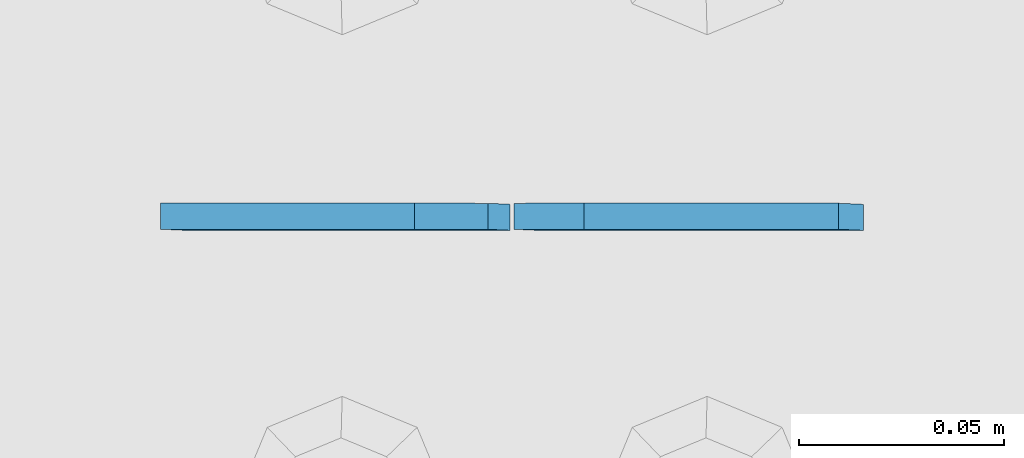
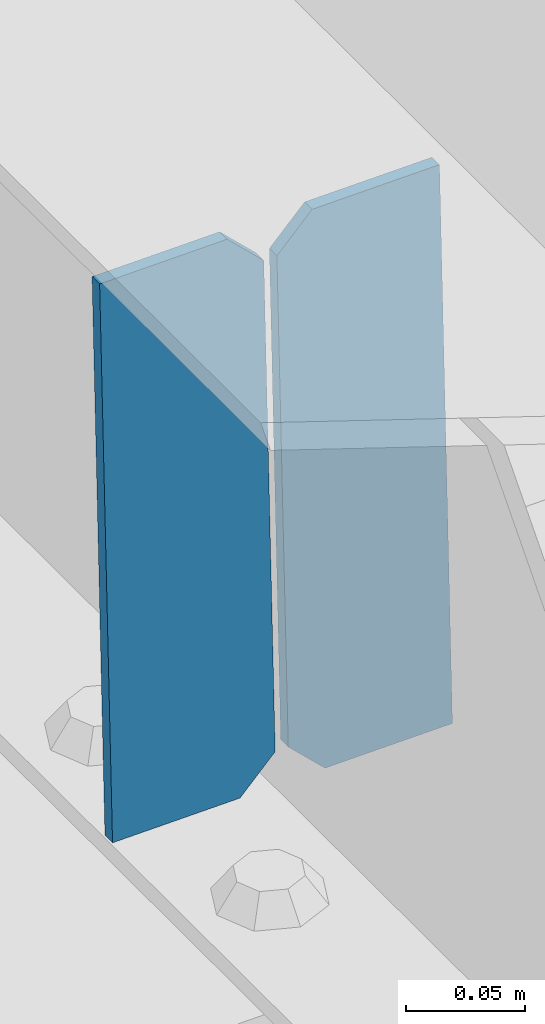
# One storey, part 3472 of 3843: 2 plates, 1 element without a shape of its own.
"""IFC2X3 building model written with IfcOpenShell, lengths in millimetres."""

from ifc_helpers import new_model, si_unit, frame, origin_with_axes, place, context, subcontext, project, spatial, faceted_brep, material, type_object, element, aggregate, save


model = new_model("IFC2X3")

# Units and contexts
model_context = context("Model", 3, precision=1e-05, world=origin_with_axes())
body_context = subcontext(model_context, "Body", "Model", "MODEL_VIEW")
ifc_project = project(units=[si_unit("LENGTHUNIT", "METRE", prefix="MILLI"), si_unit("AREAUNIT", "SQUARE_METRE"), si_unit("VOLUMEUNIT", "CUBIC_METRE"), si_unit("MASSUNIT", "GRAM", prefix="KILO"), si_unit("TIMEUNIT", "SECOND"), si_unit("PLANEANGLEUNIT", "RADIAN"), si_unit("SOLIDANGLEUNIT", "STERADIAN"), si_unit("THERMODYNAMICTEMPERATUREUNIT", "DEGREE_CELSIUS"), si_unit("LUMINOUSINTENSITYUNIT", "LUMEN")], contexts=[model_context])

# Site, building, storey
site_placement = place(None, origin_with_axes())
site = spatial("IfcSite", under=ifc_project, at=site_placement, CompositionType="ELEMENT")
building_placement = place(site_placement, origin_with_axes())
building = spatial("IfcBuilding", under=site, at=building_placement, Name="Undefined", CompositionType="ELEMENT")
storey_placement = place(building_placement, origin_with_axes())
storey = spatial("IfcBuildingStorey", under=building, at=storey_placement, Name="Undefined", CompositionType="ELEMENT", Elevation=0.0)

# Assembly, plates
assembly_placement = place(storey_placement, origin_with_axes())
assembly = element("IfcElementAssembly", 1, at=assembly_placement, inside=storey, Name="BEAM", AssemblyPlace="NOTDEFINED", PredefinedType="RIGID_FRAME")
ifc_material = material(Name="STEEL/A572-50")
plate_type = type_object("IfcPlateType", PredefinedType="NOTDEFINED")
plate_1_placement = place(assembly_placement, frame((54279.5464783436, 92214.2618382584, 45804.6277035639), z_axis=(-0.0211520977917899, 0.00096162699988054, 0.999775806884983), x_axis=(-0.999776269351802, -2.03449999561139e-05, -0.0211520880074371)))
plate_1 = element("IfcPlate", 2, at=plate_1_placement, type_object=plate_type, material=ifc_material, Name="STIFFENER", context=body_context, shape_type="Brep", body=[
    faceted_brep([(0.0, -3.17499999999927, 0.0), (6.83940015733242e-10, -3.17499999996653, 288.924999998613), (6.54836185276508e-10, 3.17500000001746, 288.924999998591), (0.0, 3.17499999999927, 0.0), (61.9125003828667, -3.17499999997744, 288.924999998599), (61.9125003828522, 3.17500000002838, 288.924999998584), (79.3750000013097, -3.17499999997744, 271.462500380039), (79.375000001266, 3.17500000002838, 271.462500380017), (79.375000000713, -3.17499999999927, 17.4624996185448), (79.3750000006694, 3.17500000000291, 17.462499618523), (61.9125003821828, -3.17499999999563, -1.45519152283669e-11), (61.9125003821682, 3.17500000000655, -2.91038304567337e-11)], [[[0, 1, 2, 3]], [[1, 4, 5, 2]], [[4, 6, 7, 5]], [[6, 8, 9, 7]], [[8, 10, 11, 9]], [[10, 0, 3, 11]], [[5, 7, 9, 11, 3, 2]], [[10, 8, 6, 4, 1, 0]]]),
])
plate_2_placement = place(assembly_placement, frame((54193.8406576539, 92214.2600941855, 45802.8144408018), z_axis=(-0.0211520977917899, 0.00096162699988054, 0.999775806884983), x_axis=(-0.999776269351802, -2.03449999561139e-05, -0.0211520880074371)))
plate_2 = element("IfcPlate", 3, at=plate_2_placement, type_object=plate_type, material=ifc_material, Name="STIFFENER", context=body_context, shape_type="Brep", body=[
    faceted_brep([(5.82076609134674e-11, -3.17499999999927, 17.4624996185667), (6.25732354819775e-10, -3.17499999997744, 271.462500380054), (5.82076609134674e-10, 3.17500000002474, 271.462500380039), (0.0, 3.17500000000655, 17.4624996185521), (17.462499619156, -3.17499999997744, 288.924999998606), (17.4624996191269, 3.17500000002474, 288.924999998591), (79.3750000013242, -3.17500000025029, 288.924999998591), (79.3750000013097, 3.1749999997337, 288.92499999857), (79.3750000006548, -3.17500000026484, -2.18278728425503e-11), (79.3750000006403, 3.17499999969732, -2.91038304567337e-11), (17.4624996184866, -3.17500000000291, 7.27595761418343e-12), (17.462499618443, 3.17500000000291, -7.27595761418343e-12)], [[[0, 1, 2, 3]], [[1, 4, 5, 2]], [[4, 6, 7, 5]], [[6, 8, 9, 7]], [[8, 10, 11, 9]], [[10, 0, 3, 11]], [[5, 7, 9, 11, 3, 2]], [[10, 8, 6, 4, 1, 0]]]),
])
aggregate(assembly, [plate_1, plate_2])

save(model, "model.ifc")
